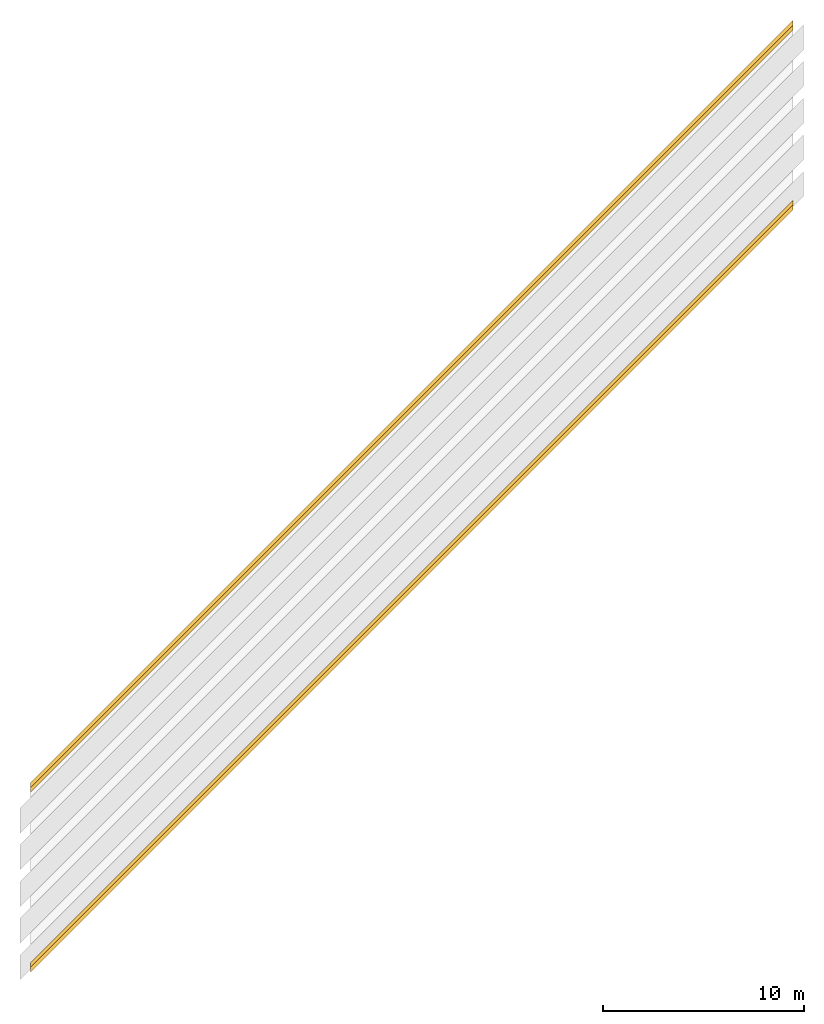
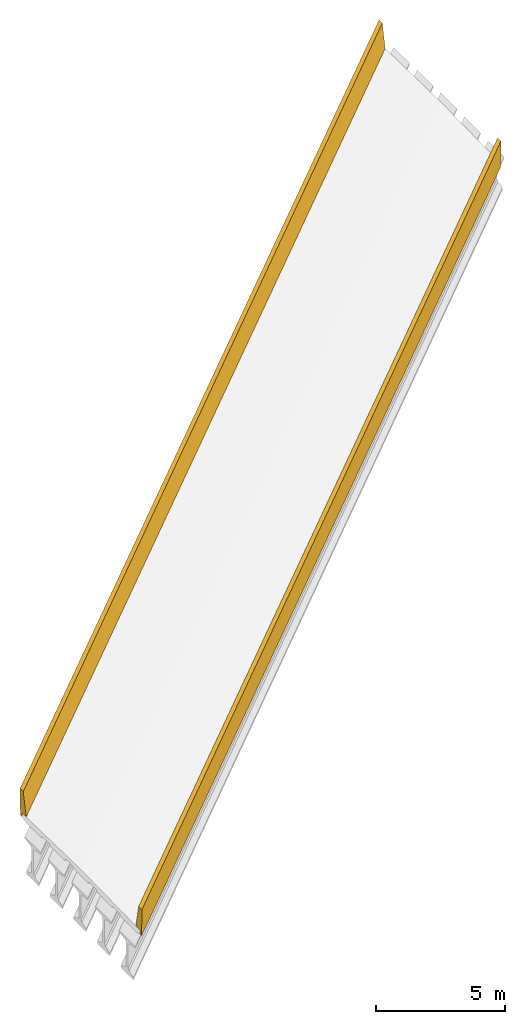
# Not in any storey, part 3 of 3: 2 railings.
"""IFC4X3_ADD2 model written with IfcOpenShell, lengths in metres."""

from ifc_helpers import new_model, entity, si_unit, direction, origin_with_axes, place, context, project, spatial, element, save


model = new_model("IFC4X3_ADD2")

# Units and contexts
model_context = context("Model", 3, precision=1e-05, world=origin_with_axes(), true_north=direction((0.0, 1.0)))
ifc_project = project(units=[si_unit("LENGTHUNIT", "METRE"), si_unit("PLANEANGLEUNIT", "RADIAN")], contexts=[model_context])

# Site, bridge, bridge part
placement = place(None, origin_with_axes())
site = spatial("IfcSite", under=ifc_project, at=placement, CompositionType="ELEMENT")
bridge = spatial("IfcBridge", under=site, CompositionType="COMPLEX", PredefinedType="GIRDER")
bridge_part = spatial("IfcBridgePart", under=bridge, CompositionType="PARTIAL", PredefinedType="SUPERSTRUCTURE", UsageType="LONGITUDINAL")

# Railings
gradient_curve_1 = entity("IfcGradientCurve", [entity("IfcCurveSegment", "CONTSAMEGRADIENT", entity("IfcAxis2Placement2D", entity("IfcCartesianPoint", [0.0, 0.0]), entity("IfcDirection", [1.0, 0.0])), entity("IfcLengthMeasure", 0.0), entity("IfcLengthMeasure", 139.624), entity("IfcLine", entity("IfcCartesianPoint", [0.0, 0.0]), entity("IfcVector", entity("IfcDirection", [1.0, 0.0]), 1.0))), entity("IfcCurveSegment", "DISCONTINUOUS", entity("IfcAxis2Placement2D", entity("IfcCartesianPoint", [0.0, 0.0]), entity("IfcDirection", [1.0, 0.0])), entity("IfcLengthMeasure", 0.0), entity("IfcLengthMeasure", 0.0), entity("IfcLine", entity("IfcCartesianPoint", [0.0, 0.0]), entity("IfcVector", entity("IfcDirection", [1.0, 0.0]), 1.0)))], False, entity("IfcCompositeCurve", [entity("IfcCurveSegment", "CONTSAMEGRADIENT", entity("IfcAxis2Placement2D", entity("IfcCartesianPoint", [-39.624, 0.0]), entity("IfcDirection", [1.0, 0.0])), entity("IfcLengthMeasure", 0.0), entity("IfcLengthMeasure", 139.624), entity("IfcLine", entity("IfcCartesianPoint", [0.0, 0.0]), entity("IfcVector", entity("IfcDirection", [1.0, 0.0]), 1.0))), entity("IfcCurveSegment", "DISCONTINUOUS", entity("IfcAxis2Placement2D", entity("IfcCartesianPoint", [100.0, 0.0]), entity("IfcDirection", [1.0, 0.0])), entity("IfcLengthMeasure", 0.0), entity("IfcLengthMeasure", 0.0), entity("IfcLine", entity("IfcCartesianPoint", [0.0, 0.0]), entity("IfcVector", entity("IfcDirection", [1.0, 0.0]), 1.0)))], False))
cartesian_point_1 = entity("IfcCartesianPoint", [-4.572, -0.09144])
cartesian_point_2 = entity("IfcCartesianPoint", [-4.572, -0.09144])
element("IfcRailing", 1, at=placement, inside=bridge_part, Name="Left Railing", PredefinedType="GUARDRAIL", context=model_context, shape_type="AdvancedSweptSolid", body=[
    entity("IfcSectionedSolidHorizontal", gradient_curve_1, [entity("IfcArbitraryClosedProfileDef", "AREA", None, entity("IfcPolyline", [cartesian_point_1, entity("IfcCartesianPoint", [-4.2418660201946, -0.084837320403892]), entity("IfcCartesianPoint", [-4.46635712646227, 0.977686196139021]), entity("IfcCartesianPoint", [-4.72030634169719, 0.972607211834322]), entity("IfcCartesianPoint", [-4.69541931860417, -0.271743942816794]), entity("IfcCartesianPoint", [-4.56844471098671, -0.269204450664445]), cartesian_point_1])), entity("IfcArbitraryClosedProfileDef", "AREA", None, entity("IfcPolyline", [cartesian_point_2, entity("IfcCartesianPoint", [-4.2418660201946, -0.084837320403892]), entity("IfcCartesianPoint", [-4.46635712646227, 0.977686196139021]), entity("IfcCartesianPoint", [-4.72030634169719, 0.972607211834322]), entity("IfcCartesianPoint", [-4.69541931860417, -0.271743942816794]), entity("IfcCartesianPoint", [-4.56844471098671, -0.269204450664445]), cartesian_point_2]))], [entity("IfcAxis2PlacementLinear", entity("IfcPointByDistanceExpression", entity("IfcLengthMeasure", 40.4495), None, None, None, gradient_curve_1)), entity("IfcAxis2PlacementLinear", entity("IfcPointByDistanceExpression", entity("IfcLengthMeasure", 78.4225), None, None, None, gradient_curve_1))]),
])
gradient_curve_2 = entity("IfcGradientCurve", [entity("IfcCurveSegment", "CONTSAMEGRADIENT", entity("IfcAxis2Placement2D", entity("IfcCartesianPoint", [0.0, 0.0]), entity("IfcDirection", [1.0, 0.0])), entity("IfcLengthMeasure", 0.0), entity("IfcLengthMeasure", 139.624), entity("IfcLine", entity("IfcCartesianPoint", [0.0, 0.0]), entity("IfcVector", entity("IfcDirection", [1.0, 0.0]), 1.0))), entity("IfcCurveSegment", "DISCONTINUOUS", entity("IfcAxis2Placement2D", entity("IfcCartesianPoint", [0.0, 0.0]), entity("IfcDirection", [1.0, 0.0])), entity("IfcLengthMeasure", 0.0), entity("IfcLengthMeasure", 0.0), entity("IfcLine", entity("IfcCartesianPoint", [0.0, 0.0]), entity("IfcVector", entity("IfcDirection", [1.0, 0.0]), 1.0)))], False, entity("IfcCompositeCurve", [entity("IfcCurveSegment", "CONTSAMEGRADIENT", entity("IfcAxis2Placement2D", entity("IfcCartesianPoint", [-39.624, 0.0]), entity("IfcDirection", [1.0, 0.0])), entity("IfcLengthMeasure", 0.0), entity("IfcLengthMeasure", 139.624), entity("IfcLine", entity("IfcCartesianPoint", [0.0, 0.0]), entity("IfcVector", entity("IfcDirection", [1.0, 0.0]), 1.0))), entity("IfcCurveSegment", "DISCONTINUOUS", entity("IfcAxis2Placement2D", entity("IfcCartesianPoint", [100.0, 0.0]), entity("IfcDirection", [1.0, 0.0])), entity("IfcLengthMeasure", 0.0), entity("IfcLengthMeasure", 0.0), entity("IfcLine", entity("IfcCartesianPoint", [0.0, 0.0]), entity("IfcVector", entity("IfcDirection", [1.0, 0.0]), 1.0)))], False))
cartesian_point_3 = entity("IfcCartesianPoint", [4.56844471098671, -0.269204450664445])
cartesian_point_4 = entity("IfcCartesianPoint", [4.56844471098671, -0.269204450664445])
element("IfcRailing", 2, at=placement, inside=bridge_part, Name="Right Railing", PredefinedType="GUARDRAIL", context=model_context, shape_type="AdvancedSweptSolid", body=[
    entity("IfcSectionedSolidHorizontal", gradient_curve_2, [entity("IfcArbitraryClosedProfileDef", "AREA", None, entity("IfcPolyline", [cartesian_point_3, entity("IfcCartesianPoint", [4.69541931860417, -0.271743942816794]), entity("IfcCartesianPoint", [4.72030634169719, 0.972607211834322]), entity("IfcCartesianPoint", [4.46635712646227, 0.977686196139021]), entity("IfcCartesianPoint", [4.2418660201946, -0.084837320403892]), entity("IfcCartesianPoint", [4.572, -0.09144]), cartesian_point_3])), entity("IfcArbitraryClosedProfileDef", "AREA", None, entity("IfcPolyline", [cartesian_point_4, entity("IfcCartesianPoint", [4.69541931860417, -0.271743942816794]), entity("IfcCartesianPoint", [4.72030634169719, 0.972607211834322]), entity("IfcCartesianPoint", [4.46635712646227, 0.977686196139021]), entity("IfcCartesianPoint", [4.2418660201946, -0.084837320403892]), entity("IfcCartesianPoint", [4.572, -0.09144]), cartesian_point_4]))], [entity("IfcAxis2PlacementLinear", entity("IfcPointByDistanceExpression", entity("IfcLengthMeasure", 40.4495), None, None, None, gradient_curve_2)), entity("IfcAxis2PlacementLinear", entity("IfcPointByDistanceExpression", entity("IfcLengthMeasure", 78.4225), None, None, None, gradient_curve_2))]),
])

save(model, "model.ifc")
